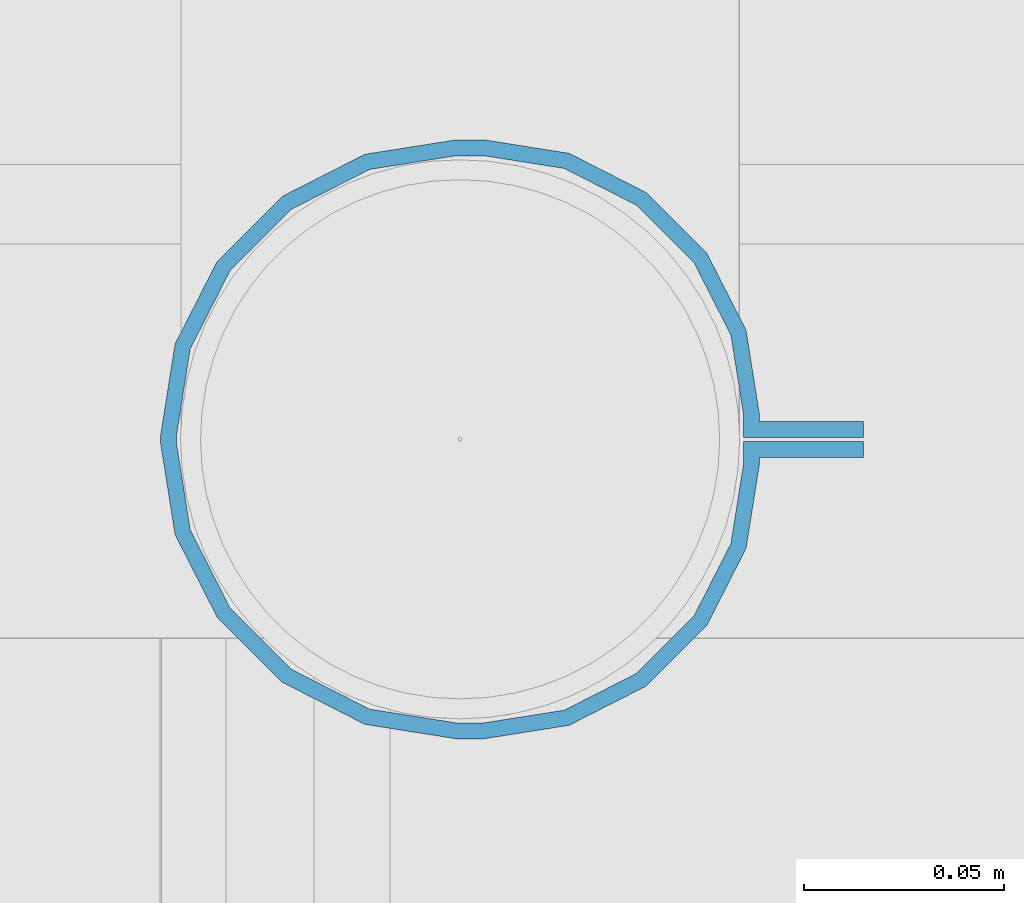
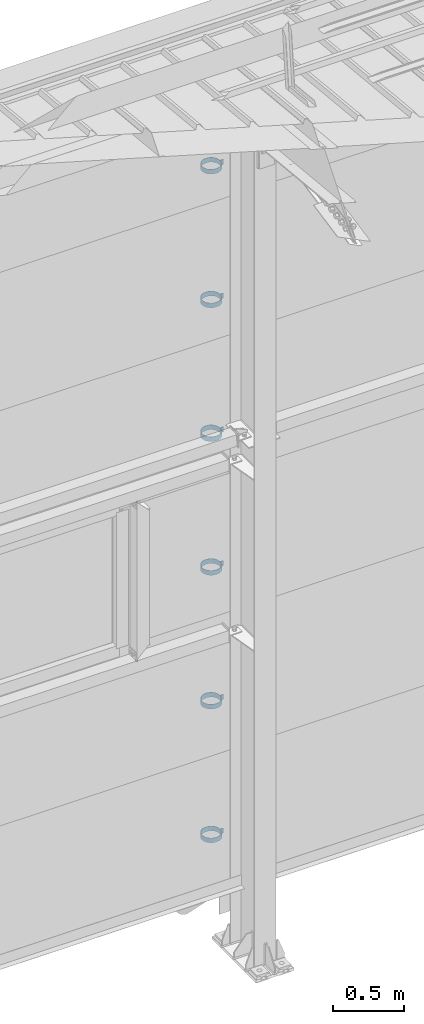
# One storey, part 319 of 709: 6 beams, 6 elements without a shape of their own.
"""IFC4 building model written with IfcOpenShell, lengths in millimetres."""

from ifc_helpers import new_model, si_unit, direction, frame, origin_with_axes, place, context, subcontext, project, spatial, polygons, material, element, aggregate, save


model = new_model("IFC4")

# Units and contexts
model_context = context("Model", 3, precision=0.2, world=origin_with_axes(), true_north=direction((0.0, 1.0)))
body_context = subcontext(model_context, "Body", "Model", "MODEL_VIEW")
ifc_project = project(units=[si_unit("LENGTHUNIT", "METRE", prefix="MILLI"), si_unit("AREAUNIT", "SQUARE_METRE"), si_unit("VOLUMEUNIT", "CUBIC_METRE"), si_unit("MASSUNIT", "GRAM", prefix="KILO"), si_unit("TIMEUNIT", "SECOND"), si_unit("PLANEANGLEUNIT", "RADIAN"), si_unit("SOLIDANGLEUNIT", "STERADIAN"), si_unit("THERMODYNAMICTEMPERATUREUNIT", "DEGREE_CELSIUS"), si_unit("LUMINOUSINTENSITYUNIT", "LUMEN")], contexts=[model_context])

# Site, building, storey
site_placement = place(None, origin_with_axes())
site = spatial("IfcSite", under=ifc_project, at=site_placement, CompositionType="ELEMENT")
building_placement = place(site_placement, origin_with_axes())
building = spatial("IfcBuilding", under=site, at=building_placement, Name="Undefined", CompositionType="ELEMENT")
storey_placement = place(building_placement, origin_with_axes())
storey = spatial("IfcBuildingStorey", under=building, at=storey_placement, Name="Undefined", CompositionType="ELEMENT", Elevation=0.0)

# Assembly, beam
assembly_1_placement = place(storey_placement, frame((34101.0, 22422.5, 6226.92297), z_axis=(0.0, 1.0, 0.0), x_axis=(-1.0, 0.0, 0.0)))
assembly_1 = element("IfcElementAssembly", 1, at=assembly_1_placement, inside=storey)
ifc_material = material(Name="Steel_Undefined", Category="STEEL")
beam_1_placement = place(assembly_1_placement, origin_with_axes())
beam_1 = element("IfcBeam", 2, at=beam_1_placement, material=ifc_material, ObjectType="616", context=body_context, shape_type="Tessellation", body=[
    polygons([(0.0, -20.0, 2.0), (0.0, 20.0, 2.0), (0.0, 20.0, -2.0), (0.0, -20.0, -2.0), (30.0, 20.0, -2.0), (30.0, -20.0, -2.0), (26.0, -20.0, 2.0), (26.0, 20.0, 2.0), (30.0, 20.0, 3.5), (30.0, -20.0, 3.5), (26.0, -20.0, 3.5), (26.0, 20.0, 3.5), (33.18133, 20.0, 23.5861), (33.18133, -20.0, 23.5861), (29.3771, -20.0, 24.82217), (29.3771, 20.0, 24.82217), (39.17783, -20.0, 44.05718), (39.17783, 20.0, 44.05718), (42.4139, 20.0, 41.70604), (42.4139, -20.0, 41.70604), (54.44282, -20.0, 59.32217), (54.44282, 20.0, 59.32217), (56.79396, 20.0, 56.0861), (56.79396, -20.0, 56.0861), (73.67783, -20.0, 69.1229), (73.67783, 20.0, 69.1229), (74.9139, 20.0, 65.31867), (74.9139, -20.0, 65.31867), (95.0, -20.0, 72.5), (95.0, 20.0, 72.5), (95.0, 20.0, 68.5), (95.0, -20.0, 68.5), (102.0, 20.0, 68.5), (102.0, -20.0, 68.5), (102.0, -20.0, 72.5), (102.0, 20.0, 72.5), (123.63119, 20.0, 65.07396), (123.63119, -20.0, 65.07396), (124.86726, -20.0, 68.87818), (124.86726, 20.0, 68.87818), (145.49611, -20.0, 58.36726), (145.49611, 20.0, 58.36726), (143.14497, 20.0, 55.13119), (143.14497, -20.0, 55.13119), (161.86726, -20.0, 41.99611), (161.86726, 20.0, 41.99611), (158.63119, 20.0, 39.64497), (158.63119, -20.0, 39.64497), (172.37818, -20.0, 21.36726), (172.37818, 20.0, 21.36726), (168.57396, 20.0, 20.13119), (168.57396, -20.0, 20.13119), (176.0, -20.0, -1.5), (176.0, 20.0, -1.5), (172.0, 20.0, -1.5), (172.0, -20.0, -1.5), (172.0, 20.0, -3.5), (172.0, -20.0, -3.5), (176.0, -20.0, -3.5), (176.0, 20.0, -3.5), (168.57396, 20.0, -25.13119), (168.57396, -20.0, -25.13119), (172.37818, -20.0, -26.36726), (172.37818, 20.0, -26.36726), (161.86726, -20.0, -46.99611), (161.86726, 20.0, -46.99611), (158.63119, 20.0, -44.64497), (158.63119, -20.0, -44.64497), (145.49611, -20.0, -63.36726), (145.49611, 20.0, -63.36726), (143.14497, 20.0, -60.13119), (143.14497, -20.0, -60.13119), (124.86726, -20.0, -73.87818), (124.86726, 20.0, -73.87818), (123.63119, 20.0, -70.07396), (123.63119, -20.0, -70.07396), (102.0, -20.0, -77.5), (102.0, 20.0, -77.5), (102.0, 20.0, -73.5), (102.0, -20.0, -73.5), (95.0, 20.0, -73.5), (95.0, -20.0, -73.5), (95.0, -20.0, -77.5), (95.0, 20.0, -77.5), (74.9139, 20.0, -70.31867), (74.9139, -20.0, -70.31867), (73.67783, -20.0, -74.1229), (73.67783, 20.0, -74.1229), (54.44282, -20.0, -64.32217), (54.44282, 20.0, -64.32217), (56.79396, 20.0, -61.0861), (56.79396, -20.0, -61.0861), (39.17783, -20.0, -49.05718), (39.17783, 20.0, -49.05718), (42.4139, 20.0, -46.70604), (42.4139, -20.0, -46.70604), (29.3771, -20.0, -29.82217), (29.3771, 20.0, -29.82217), (33.18133, 20.0, -28.5861), (33.18133, -20.0, -28.5861), (26.0, -20.0, -8.5), (26.0, 20.0, -8.5), (30.0, 20.0, -8.5), (30.0, -20.0, -8.5), (30.0, 20.0, -3.0), (30.0, -20.0, -3.0), (26.0, -20.0, -7.0), (26.0, 20.0, -7.0), (0.0, 20.0, -3.0), (0.0, -20.0, -3.0), (0.0, 20.0, -7.0), (0.0, -20.0, -7.0)], [[[1, 2, 3, 4]], [[4, 3, 5, 6]], [[2, 1, 7, 8]], [[6, 5, 9, 10]], [[8, 7, 11, 12]], [[10, 9, 13, 14]], [[12, 11, 15, 16]], [[15, 17, 18, 16]], [[13, 19, 20, 14]], [[17, 21, 22, 18]], [[19, 23, 24, 20]], [[21, 25, 26, 22]], [[23, 27, 28, 24]], [[25, 29, 30, 26]], [[27, 31, 32, 28]], [[32, 31, 33, 34]], [[30, 29, 35, 36]], [[34, 33, 37, 38]], [[36, 35, 39, 40]], [[39, 41, 42, 40]], [[37, 43, 44, 38]], [[41, 45, 46, 42]], [[43, 47, 48, 44]], [[45, 49, 50, 46]], [[47, 51, 52, 48]], [[49, 53, 54, 50]], [[51, 55, 56, 52]], [[56, 55, 57, 58]], [[54, 53, 59, 60]], [[58, 57, 61, 62]], [[60, 59, 63, 64]], [[63, 65, 66, 64]], [[61, 67, 68, 62]], [[65, 69, 70, 66]], [[67, 71, 72, 68]], [[69, 73, 74, 70]], [[71, 75, 76, 72]], [[73, 77, 78, 74]], [[75, 79, 80, 76]], [[80, 79, 81, 82]], [[78, 77, 83, 84]], [[82, 81, 85, 86]], [[84, 83, 87, 88]], [[87, 89, 90, 88]], [[85, 91, 92, 86]], [[89, 93, 94, 90]], [[91, 95, 96, 92]], [[93, 97, 98, 94]], [[95, 99, 100, 96]], [[97, 101, 102, 98]], [[99, 103, 104, 100]], [[104, 103, 105, 106]], [[102, 101, 107, 108]], [[106, 105, 109, 110]], [[105, 103, 99, 95, 91, 85, 81, 79, 75, 71, 67, 61, 57, 55, 51, 47, 43, 37, 33, 31, 27, 23, 19, 13, 9, 5, 3, 2, 8, 12, 16, 18, 22, 26, 30, 36, 40, 42, 46, 50, 54, 60, 64, 66, 70, 74, 78, 84, 88, 90, 94, 98, 102, 108, 111, 109]], [[108, 107, 112, 111]], [[107, 101, 97, 93, 89, 87, 83, 77, 73, 69, 65, 63, 59, 53, 49, 45, 41, 39, 35, 29, 25, 21, 17, 15, 11, 7, 1, 4, 6, 10, 14, 20, 24, 28, 32, 34, 38, 44, 48, 52, 56, 58, 62, 68, 72, 76, 80, 82, 86, 92, 96, 100, 104, 106, 110, 112]], [[111, 112, 110, 109]]], closed=True),
])
aggregate(assembly_1, [beam_1])

assembly_2_placement = place(storey_placement, frame((34101.0, 22422.5, 5076.92297), z_axis=(0.0, 1.0, 0.0), x_axis=(-1.0, 0.0, 0.0)))
assembly_2 = element("IfcElementAssembly", 3, at=assembly_2_placement, inside=storey)
beam_2_placement = place(assembly_2_placement, origin_with_axes())
beam_2 = element("IfcBeam", 4, at=beam_2_placement, material=ifc_material, ObjectType="616", context=body_context, shape_type="Tessellation", body=[
    polygons([(0.0, -20.0, 2.0), (0.0, 20.0, 2.0), (0.0, 20.0, -2.0), (0.0, -20.0, -2.0), (30.0, 20.0, -2.0), (30.0, -20.0, -2.0), (26.0, -20.0, 2.0), (26.0, 20.0, 2.0), (30.0, 20.0, 3.5), (30.0, -20.0, 3.5), (26.0, -20.0, 3.5), (26.0, 20.0, 3.5), (33.18133, 20.0, 23.5861), (33.18133, -20.0, 23.5861), (29.3771, -20.0, 24.82217), (29.3771, 20.0, 24.82217), (39.17783, -20.0, 44.05718), (39.17783, 20.0, 44.05718), (42.4139, 20.0, 41.70604), (42.4139, -20.0, 41.70604), (54.44282, -20.0, 59.32217), (54.44282, 20.0, 59.32217), (56.79396, 20.0, 56.0861), (56.79396, -20.0, 56.0861), (73.67783, -20.0, 69.1229), (73.67783, 20.0, 69.1229), (74.9139, 20.0, 65.31867), (74.9139, -20.0, 65.31867), (95.0, -20.0, 72.5), (95.0, 20.0, 72.5), (95.0, 20.0, 68.5), (95.0, -20.0, 68.5), (102.0, 20.0, 68.5), (102.0, -20.0, 68.5), (102.0, -20.0, 72.5), (102.0, 20.0, 72.5), (123.63119, 20.0, 65.07396), (123.63119, -20.0, 65.07396), (124.86726, -20.0, 68.87818), (124.86726, 20.0, 68.87818), (145.49611, -20.0, 58.36726), (145.49611, 20.0, 58.36726), (143.14497, 20.0, 55.13119), (143.14497, -20.0, 55.13119), (161.86726, -20.0, 41.99611), (161.86726, 20.0, 41.99611), (158.63119, 20.0, 39.64497), (158.63119, -20.0, 39.64497), (172.37818, -20.0, 21.36726), (172.37818, 20.0, 21.36726), (168.57396, 20.0, 20.13119), (168.57396, -20.0, 20.13119), (176.0, -20.0, -1.5), (176.0, 20.0, -1.5), (172.0, 20.0, -1.5), (172.0, -20.0, -1.5), (172.0, 20.0, -3.5), (172.0, -20.0, -3.5), (176.0, -20.0, -3.5), (176.0, 20.0, -3.5), (168.57396, 20.0, -25.13119), (168.57396, -20.0, -25.13119), (172.37818, -20.0, -26.36726), (172.37818, 20.0, -26.36726), (161.86726, -20.0, -46.99611), (161.86726, 20.0, -46.99611), (158.63119, 20.0, -44.64497), (158.63119, -20.0, -44.64497), (145.49611, -20.0, -63.36726), (145.49611, 20.0, -63.36726), (143.14497, 20.0, -60.13119), (143.14497, -20.0, -60.13119), (124.86726, -20.0, -73.87818), (124.86726, 20.0, -73.87818), (123.63119, 20.0, -70.07396), (123.63119, -20.0, -70.07396), (102.0, -20.0, -77.5), (102.0, 20.0, -77.5), (102.0, 20.0, -73.5), (102.0, -20.0, -73.5), (95.0, 20.0, -73.5), (95.0, -20.0, -73.5), (95.0, -20.0, -77.5), (95.0, 20.0, -77.5), (74.9139, 20.0, -70.31867), (74.9139, -20.0, -70.31867), (73.67783, -20.0, -74.1229), (73.67783, 20.0, -74.1229), (54.44282, -20.0, -64.32217), (54.44282, 20.0, -64.32217), (56.79396, 20.0, -61.0861), (56.79396, -20.0, -61.0861), (39.17783, -20.0, -49.05718), (39.17783, 20.0, -49.05718), (42.4139, 20.0, -46.70604), (42.4139, -20.0, -46.70604), (29.3771, -20.0, -29.82217), (29.3771, 20.0, -29.82217), (33.18133, 20.0, -28.5861), (33.18133, -20.0, -28.5861), (26.0, -20.0, -8.5), (26.0, 20.0, -8.5), (30.0, 20.0, -8.5), (30.0, -20.0, -8.5), (30.0, 20.0, -3.0), (30.0, -20.0, -3.0), (26.0, -20.0, -7.0), (26.0, 20.0, -7.0), (0.0, 20.0, -3.0), (0.0, -20.0, -3.0), (0.0, 20.0, -7.0), (0.0, -20.0, -7.0)], [[[1, 2, 3, 4]], [[4, 3, 5, 6]], [[2, 1, 7, 8]], [[6, 5, 9, 10]], [[8, 7, 11, 12]], [[10, 9, 13, 14]], [[12, 11, 15, 16]], [[15, 17, 18, 16]], [[13, 19, 20, 14]], [[17, 21, 22, 18]], [[19, 23, 24, 20]], [[21, 25, 26, 22]], [[23, 27, 28, 24]], [[25, 29, 30, 26]], [[27, 31, 32, 28]], [[32, 31, 33, 34]], [[30, 29, 35, 36]], [[34, 33, 37, 38]], [[36, 35, 39, 40]], [[39, 41, 42, 40]], [[37, 43, 44, 38]], [[41, 45, 46, 42]], [[43, 47, 48, 44]], [[45, 49, 50, 46]], [[47, 51, 52, 48]], [[49, 53, 54, 50]], [[51, 55, 56, 52]], [[56, 55, 57, 58]], [[54, 53, 59, 60]], [[58, 57, 61, 62]], [[60, 59, 63, 64]], [[63, 65, 66, 64]], [[61, 67, 68, 62]], [[65, 69, 70, 66]], [[67, 71, 72, 68]], [[69, 73, 74, 70]], [[71, 75, 76, 72]], [[73, 77, 78, 74]], [[75, 79, 80, 76]], [[80, 79, 81, 82]], [[78, 77, 83, 84]], [[82, 81, 85, 86]], [[84, 83, 87, 88]], [[87, 89, 90, 88]], [[85, 91, 92, 86]], [[89, 93, 94, 90]], [[91, 95, 96, 92]], [[93, 97, 98, 94]], [[95, 99, 100, 96]], [[97, 101, 102, 98]], [[99, 103, 104, 100]], [[104, 103, 105, 106]], [[102, 101, 107, 108]], [[106, 105, 109, 110]], [[105, 103, 99, 95, 91, 85, 81, 79, 75, 71, 67, 61, 57, 55, 51, 47, 43, 37, 33, 31, 27, 23, 19, 13, 9, 5, 3, 2, 8, 12, 16, 18, 22, 26, 30, 36, 40, 42, 46, 50, 54, 60, 64, 66, 70, 74, 78, 84, 88, 90, 94, 98, 102, 108, 111, 109]], [[108, 107, 112, 111]], [[107, 101, 97, 93, 89, 87, 83, 77, 73, 69, 65, 63, 59, 53, 49, 45, 41, 39, 35, 29, 25, 21, 17, 15, 11, 7, 1, 4, 6, 10, 14, 20, 24, 28, 32, 34, 38, 44, 48, 52, 56, 58, 62, 68, 72, 76, 80, 82, 86, 92, 96, 100, 104, 106, 110, 112]], [[111, 112, 110, 109]]], closed=True),
])
aggregate(assembly_2, [beam_2])

assembly_3_placement = place(storey_placement, frame((34101.0, 22422.5, 3926.92297), z_axis=(0.0, 1.0, 0.0), x_axis=(-1.0, 0.0, 0.0)))
assembly_3 = element("IfcElementAssembly", 5, at=assembly_3_placement, inside=storey)
beam_3_placement = place(assembly_3_placement, origin_with_axes())
beam_3 = element("IfcBeam", 6, at=beam_3_placement, material=ifc_material, ObjectType="616", context=body_context, shape_type="Tessellation", body=[
    polygons([(0.0, -20.0, 2.0), (0.0, 20.0, 2.0), (0.0, 20.0, -2.0), (0.0, -20.0, -2.0), (30.0, 20.0, -2.0), (30.0, -20.0, -2.0), (26.0, -20.0, 2.0), (26.0, 20.0, 2.0), (30.0, 20.0, 3.5), (30.0, -20.0, 3.5), (26.0, -20.0, 3.5), (26.0, 20.0, 3.5), (33.18133, 20.0, 23.5861), (33.18133, -20.0, 23.5861), (29.3771, -20.0, 24.82217), (29.3771, 20.0, 24.82217), (39.17783, -20.0, 44.05718), (39.17783, 20.0, 44.05718), (42.4139, 20.0, 41.70604), (42.4139, -20.0, 41.70604), (54.44282, -20.0, 59.32217), (54.44282, 20.0, 59.32217), (56.79396, 20.0, 56.0861), (56.79396, -20.0, 56.0861), (73.67783, -20.0, 69.1229), (73.67783, 20.0, 69.1229), (74.9139, 20.0, 65.31867), (74.9139, -20.0, 65.31867), (95.0, -20.0, 72.5), (95.0, 20.0, 72.5), (95.0, 20.0, 68.5), (95.0, -20.0, 68.5), (102.0, 20.0, 68.5), (102.0, -20.0, 68.5), (102.0, -20.0, 72.5), (102.0, 20.0, 72.5), (123.63119, 20.0, 65.07396), (123.63119, -20.0, 65.07396), (124.86726, -20.0, 68.87818), (124.86726, 20.0, 68.87818), (145.49611, -20.0, 58.36726), (145.49611, 20.0, 58.36726), (143.14497, 20.0, 55.13119), (143.14497, -20.0, 55.13119), (161.86726, -20.0, 41.99611), (161.86726, 20.0, 41.99611), (158.63119, 20.0, 39.64497), (158.63119, -20.0, 39.64497), (172.37818, -20.0, 21.36726), (172.37818, 20.0, 21.36726), (168.57396, 20.0, 20.13119), (168.57396, -20.0, 20.13119), (176.0, -20.0, -1.5), (176.0, 20.0, -1.5), (172.0, 20.0, -1.5), (172.0, -20.0, -1.5), (172.0, 20.0, -3.5), (172.0, -20.0, -3.5), (176.0, -20.0, -3.5), (176.0, 20.0, -3.5), (168.57396, 20.0, -25.13119), (168.57396, -20.0, -25.13119), (172.37818, -20.0, -26.36726), (172.37818, 20.0, -26.36726), (161.86726, -20.0, -46.99611), (161.86726, 20.0, -46.99611), (158.63119, 20.0, -44.64497), (158.63119, -20.0, -44.64497), (145.49611, -20.0, -63.36726), (145.49611, 20.0, -63.36726), (143.14497, 20.0, -60.13119), (143.14497, -20.0, -60.13119), (124.86726, -20.0, -73.87818), (124.86726, 20.0, -73.87818), (123.63119, 20.0, -70.07396), (123.63119, -20.0, -70.07396), (102.0, -20.0, -77.5), (102.0, 20.0, -77.5), (102.0, 20.0, -73.5), (102.0, -20.0, -73.5), (95.0, 20.0, -73.5), (95.0, -20.0, -73.5), (95.0, -20.0, -77.5), (95.0, 20.0, -77.5), (74.9139, 20.0, -70.31867), (74.9139, -20.0, -70.31867), (73.67783, -20.0, -74.1229), (73.67783, 20.0, -74.1229), (54.44282, -20.0, -64.32217), (54.44282, 20.0, -64.32217), (56.79396, 20.0, -61.0861), (56.79396, -20.0, -61.0861), (39.17783, -20.0, -49.05718), (39.17783, 20.0, -49.05718), (42.4139, 20.0, -46.70604), (42.4139, -20.0, -46.70604), (29.3771, -20.0, -29.82217), (29.3771, 20.0, -29.82217), (33.18133, 20.0, -28.5861), (33.18133, -20.0, -28.5861), (26.0, -20.0, -8.5), (26.0, 20.0, -8.5), (30.0, 20.0, -8.5), (30.0, -20.0, -8.5), (30.0, 20.0, -3.0), (30.0, -20.0, -3.0), (26.0, -20.0, -7.0), (26.0, 20.0, -7.0), (0.0, 20.0, -3.0), (0.0, -20.0, -3.0), (0.0, 20.0, -7.0), (0.0, -20.0, -7.0)], [[[1, 2, 3, 4]], [[4, 3, 5, 6]], [[2, 1, 7, 8]], [[6, 5, 9, 10]], [[8, 7, 11, 12]], [[10, 9, 13, 14]], [[12, 11, 15, 16]], [[15, 17, 18, 16]], [[13, 19, 20, 14]], [[17, 21, 22, 18]], [[19, 23, 24, 20]], [[21, 25, 26, 22]], [[23, 27, 28, 24]], [[25, 29, 30, 26]], [[27, 31, 32, 28]], [[32, 31, 33, 34]], [[30, 29, 35, 36]], [[34, 33, 37, 38]], [[36, 35, 39, 40]], [[39, 41, 42, 40]], [[37, 43, 44, 38]], [[41, 45, 46, 42]], [[43, 47, 48, 44]], [[45, 49, 50, 46]], [[47, 51, 52, 48]], [[49, 53, 54, 50]], [[51, 55, 56, 52]], [[56, 55, 57, 58]], [[54, 53, 59, 60]], [[58, 57, 61, 62]], [[60, 59, 63, 64]], [[63, 65, 66, 64]], [[61, 67, 68, 62]], [[65, 69, 70, 66]], [[67, 71, 72, 68]], [[69, 73, 74, 70]], [[71, 75, 76, 72]], [[73, 77, 78, 74]], [[75, 79, 80, 76]], [[80, 79, 81, 82]], [[78, 77, 83, 84]], [[82, 81, 85, 86]], [[84, 83, 87, 88]], [[87, 89, 90, 88]], [[85, 91, 92, 86]], [[89, 93, 94, 90]], [[91, 95, 96, 92]], [[93, 97, 98, 94]], [[95, 99, 100, 96]], [[97, 101, 102, 98]], [[99, 103, 104, 100]], [[104, 103, 105, 106]], [[102, 101, 107, 108]], [[106, 105, 109, 110]], [[105, 103, 99, 95, 91, 85, 81, 79, 75, 71, 67, 61, 57, 55, 51, 47, 43, 37, 33, 31, 27, 23, 19, 13, 9, 5, 3, 2, 8, 12, 16, 18, 22, 26, 30, 36, 40, 42, 46, 50, 54, 60, 64, 66, 70, 74, 78, 84, 88, 90, 94, 98, 102, 108, 111, 109]], [[108, 107, 112, 111]], [[107, 101, 97, 93, 89, 87, 83, 77, 73, 69, 65, 63, 59, 53, 49, 45, 41, 39, 35, 29, 25, 21, 17, 15, 11, 7, 1, 4, 6, 10, 14, 20, 24, 28, 32, 34, 38, 44, 48, 52, 56, 58, 62, 68, 72, 76, 80, 82, 86, 92, 96, 100, 104, 106, 110, 112]], [[111, 112, 110, 109]]], closed=True),
])
aggregate(assembly_3, [beam_3])

assembly_4_placement = place(storey_placement, frame((34101.0, 22422.5, 2776.92297), z_axis=(0.0, 1.0, 0.0), x_axis=(-1.0, 0.0, 0.0)))
assembly_4 = element("IfcElementAssembly", 7, at=assembly_4_placement, inside=storey)
beam_4_placement = place(assembly_4_placement, origin_with_axes())
beam_4 = element("IfcBeam", 8, at=beam_4_placement, material=ifc_material, ObjectType="616", context=body_context, shape_type="Tessellation", body=[
    polygons([(0.0, -20.0, 2.0), (0.0, 20.0, 2.0), (0.0, 20.0, -2.0), (0.0, -20.0, -2.0), (30.0, 20.0, -2.0), (30.0, -20.0, -2.0), (26.0, -20.0, 2.0), (26.0, 20.0, 2.0), (30.0, 20.0, 3.5), (30.0, -20.0, 3.5), (26.0, -20.0, 3.5), (26.0, 20.0, 3.5), (33.18133, 20.0, 23.5861), (33.18133, -20.0, 23.5861), (29.3771, -20.0, 24.82217), (29.3771, 20.0, 24.82217), (39.17783, -20.0, 44.05718), (39.17783, 20.0, 44.05718), (42.4139, 20.0, 41.70604), (42.4139, -20.0, 41.70604), (54.44282, -20.0, 59.32217), (54.44282, 20.0, 59.32217), (56.79396, 20.0, 56.0861), (56.79396, -20.0, 56.0861), (73.67783, -20.0, 69.1229), (73.67783, 20.0, 69.1229), (74.9139, 20.0, 65.31867), (74.9139, -20.0, 65.31867), (95.0, -20.0, 72.5), (95.0, 20.0, 72.5), (95.0, 20.0, 68.5), (95.0, -20.0, 68.5), (102.0, 20.0, 68.5), (102.0, -20.0, 68.5), (102.0, -20.0, 72.5), (102.0, 20.0, 72.5), (123.63119, 20.0, 65.07396), (123.63119, -20.0, 65.07396), (124.86726, -20.0, 68.87818), (124.86726, 20.0, 68.87818), (145.49611, -20.0, 58.36726), (145.49611, 20.0, 58.36726), (143.14497, 20.0, 55.13119), (143.14497, -20.0, 55.13119), (161.86726, -20.0, 41.99611), (161.86726, 20.0, 41.99611), (158.63119, 20.0, 39.64497), (158.63119, -20.0, 39.64497), (172.37818, -20.0, 21.36726), (172.37818, 20.0, 21.36726), (168.57396, 20.0, 20.13119), (168.57396, -20.0, 20.13119), (176.0, -20.0, -1.5), (176.0, 20.0, -1.5), (172.0, 20.0, -1.5), (172.0, -20.0, -1.5), (172.0, 20.0, -3.5), (172.0, -20.0, -3.5), (176.0, -20.0, -3.5), (176.0, 20.0, -3.5), (168.57396, 20.0, -25.13119), (168.57396, -20.0, -25.13119), (172.37818, -20.0, -26.36726), (172.37818, 20.0, -26.36726), (161.86726, -20.0, -46.99611), (161.86726, 20.0, -46.99611), (158.63119, 20.0, -44.64497), (158.63119, -20.0, -44.64497), (145.49611, -20.0, -63.36726), (145.49611, 20.0, -63.36726), (143.14497, 20.0, -60.13119), (143.14497, -20.0, -60.13119), (124.86726, -20.0, -73.87818), (124.86726, 20.0, -73.87818), (123.63119, 20.0, -70.07396), (123.63119, -20.0, -70.07396), (102.0, -20.0, -77.5), (102.0, 20.0, -77.5), (102.0, 20.0, -73.5), (102.0, -20.0, -73.5), (95.0, 20.0, -73.5), (95.0, -20.0, -73.5), (95.0, -20.0, -77.5), (95.0, 20.0, -77.5), (74.9139, 20.0, -70.31867), (74.9139, -20.0, -70.31867), (73.67783, -20.0, -74.1229), (73.67783, 20.0, -74.1229), (54.44282, -20.0, -64.32217), (54.44282, 20.0, -64.32217), (56.79396, 20.0, -61.0861), (56.79396, -20.0, -61.0861), (39.17783, -20.0, -49.05718), (39.17783, 20.0, -49.05718), (42.4139, 20.0, -46.70604), (42.4139, -20.0, -46.70604), (29.3771, -20.0, -29.82217), (29.3771, 20.0, -29.82217), (33.18133, 20.0, -28.5861), (33.18133, -20.0, -28.5861), (26.0, -20.0, -8.5), (26.0, 20.0, -8.5), (30.0, 20.0, -8.5), (30.0, -20.0, -8.5), (30.0, 20.0, -3.0), (30.0, -20.0, -3.0), (26.0, -20.0, -7.0), (26.0, 20.0, -7.0), (0.0, 20.0, -3.0), (0.0, -20.0, -3.0), (0.0, 20.0, -7.0), (0.0, -20.0, -7.0)], [[[1, 2, 3, 4]], [[4, 3, 5, 6]], [[2, 1, 7, 8]], [[6, 5, 9, 10]], [[8, 7, 11, 12]], [[10, 9, 13, 14]], [[12, 11, 15, 16]], [[15, 17, 18, 16]], [[13, 19, 20, 14]], [[17, 21, 22, 18]], [[19, 23, 24, 20]], [[21, 25, 26, 22]], [[23, 27, 28, 24]], [[25, 29, 30, 26]], [[27, 31, 32, 28]], [[32, 31, 33, 34]], [[30, 29, 35, 36]], [[34, 33, 37, 38]], [[36, 35, 39, 40]], [[39, 41, 42, 40]], [[37, 43, 44, 38]], [[41, 45, 46, 42]], [[43, 47, 48, 44]], [[45, 49, 50, 46]], [[47, 51, 52, 48]], [[49, 53, 54, 50]], [[51, 55, 56, 52]], [[56, 55, 57, 58]], [[54, 53, 59, 60]], [[58, 57, 61, 62]], [[60, 59, 63, 64]], [[63, 65, 66, 64]], [[61, 67, 68, 62]], [[65, 69, 70, 66]], [[67, 71, 72, 68]], [[69, 73, 74, 70]], [[71, 75, 76, 72]], [[73, 77, 78, 74]], [[75, 79, 80, 76]], [[80, 79, 81, 82]], [[78, 77, 83, 84]], [[82, 81, 85, 86]], [[84, 83, 87, 88]], [[87, 89, 90, 88]], [[85, 91, 92, 86]], [[89, 93, 94, 90]], [[91, 95, 96, 92]], [[93, 97, 98, 94]], [[95, 99, 100, 96]], [[97, 101, 102, 98]], [[99, 103, 104, 100]], [[104, 103, 105, 106]], [[102, 101, 107, 108]], [[106, 105, 109, 110]], [[105, 103, 99, 95, 91, 85, 81, 79, 75, 71, 67, 61, 57, 55, 51, 47, 43, 37, 33, 31, 27, 23, 19, 13, 9, 5, 3, 2, 8, 12, 16, 18, 22, 26, 30, 36, 40, 42, 46, 50, 54, 60, 64, 66, 70, 74, 78, 84, 88, 90, 94, 98, 102, 108, 111, 109]], [[108, 107, 112, 111]], [[107, 101, 97, 93, 89, 87, 83, 77, 73, 69, 65, 63, 59, 53, 49, 45, 41, 39, 35, 29, 25, 21, 17, 15, 11, 7, 1, 4, 6, 10, 14, 20, 24, 28, 32, 34, 38, 44, 48, 52, 56, 58, 62, 68, 72, 76, 80, 82, 86, 92, 96, 100, 104, 106, 110, 112]], [[111, 112, 110, 109]]], closed=True),
])
aggregate(assembly_4, [beam_4])

assembly_5_placement = place(storey_placement, frame((34101.0, 22422.5, 1626.92297), z_axis=(0.0, 1.0, 0.0), x_axis=(-1.0, 0.0, 0.0)))
assembly_5 = element("IfcElementAssembly", 9, at=assembly_5_placement, inside=storey)
beam_5_placement = place(assembly_5_placement, origin_with_axes())
beam_5 = element("IfcBeam", 10, at=beam_5_placement, material=ifc_material, ObjectType="616", context=body_context, shape_type="Tessellation", body=[
    polygons([(0.0, -20.0, 2.0), (0.0, 20.0, 2.0), (0.0, 20.0, -2.0), (0.0, -20.0, -2.0), (30.0, 20.0, -2.0), (30.0, -20.0, -2.0), (26.0, -20.0, 2.0), (26.0, 20.0, 2.0), (30.0, 20.0, 3.5), (30.0, -20.0, 3.5), (26.0, -20.0, 3.5), (26.0, 20.0, 3.5), (33.18133, 20.0, 23.5861), (33.18133, -20.0, 23.5861), (29.3771, -20.0, 24.82217), (29.3771, 20.0, 24.82217), (39.17783, -20.0, 44.05718), (39.17783, 20.0, 44.05718), (42.4139, 20.0, 41.70604), (42.4139, -20.0, 41.70604), (54.44282, -20.0, 59.32217), (54.44282, 20.0, 59.32217), (56.79396, 20.0, 56.0861), (56.79396, -20.0, 56.0861), (73.67783, -20.0, 69.1229), (73.67783, 20.0, 69.1229), (74.9139, 20.0, 65.31867), (74.9139, -20.0, 65.31867), (95.0, -20.0, 72.5), (95.0, 20.0, 72.5), (95.0, 20.0, 68.5), (95.0, -20.0, 68.5), (102.0, 20.0, 68.5), (102.0, -20.0, 68.5), (102.0, -20.0, 72.5), (102.0, 20.0, 72.5), (123.63119, 20.0, 65.07396), (123.63119, -20.0, 65.07396), (124.86726, -20.0, 68.87818), (124.86726, 20.0, 68.87818), (145.49611, -20.0, 58.36726), (145.49611, 20.0, 58.36726), (143.14497, 20.0, 55.13119), (143.14497, -20.0, 55.13119), (161.86726, -20.0, 41.99611), (161.86726, 20.0, 41.99611), (158.63119, 20.0, 39.64497), (158.63119, -20.0, 39.64497), (172.37818, -20.0, 21.36726), (172.37818, 20.0, 21.36726), (168.57396, 20.0, 20.13119), (168.57396, -20.0, 20.13119), (176.0, -20.0, -1.5), (176.0, 20.0, -1.5), (172.0, 20.0, -1.5), (172.0, -20.0, -1.5), (172.0, 20.0, -3.5), (172.0, -20.0, -3.5), (176.0, -20.0, -3.5), (176.0, 20.0, -3.5), (168.57396, 20.0, -25.13119), (168.57396, -20.0, -25.13119), (172.37818, -20.0, -26.36726), (172.37818, 20.0, -26.36726), (161.86726, -20.0, -46.99611), (161.86726, 20.0, -46.99611), (158.63119, 20.0, -44.64497), (158.63119, -20.0, -44.64497), (145.49611, -20.0, -63.36726), (145.49611, 20.0, -63.36726), (143.14497, 20.0, -60.13119), (143.14497, -20.0, -60.13119), (124.86726, -20.0, -73.87818), (124.86726, 20.0, -73.87818), (123.63119, 20.0, -70.07396), (123.63119, -20.0, -70.07396), (102.0, -20.0, -77.5), (102.0, 20.0, -77.5), (102.0, 20.0, -73.5), (102.0, -20.0, -73.5), (95.0, 20.0, -73.5), (95.0, -20.0, -73.5), (95.0, -20.0, -77.5), (95.0, 20.0, -77.5), (74.9139, 20.0, -70.31867), (74.9139, -20.0, -70.31867), (73.67783, -20.0, -74.1229), (73.67783, 20.0, -74.1229), (54.44282, -20.0, -64.32217), (54.44282, 20.0, -64.32217), (56.79396, 20.0, -61.0861), (56.79396, -20.0, -61.0861), (39.17783, -20.0, -49.05718), (39.17783, 20.0, -49.05718), (42.4139, 20.0, -46.70604), (42.4139, -20.0, -46.70604), (29.3771, -20.0, -29.82217), (29.3771, 20.0, -29.82217), (33.18133, 20.0, -28.5861), (33.18133, -20.0, -28.5861), (26.0, -20.0, -8.5), (26.0, 20.0, -8.5), (30.0, 20.0, -8.5), (30.0, -20.0, -8.5), (30.0, 20.0, -3.0), (30.0, -20.0, -3.0), (26.0, -20.0, -7.0), (26.0, 20.0, -7.0), (0.0, 20.0, -3.0), (0.0, -20.0, -3.0), (0.0, 20.0, -7.0), (0.0, -20.0, -7.0)], [[[1, 2, 3, 4]], [[4, 3, 5, 6]], [[2, 1, 7, 8]], [[6, 5, 9, 10]], [[8, 7, 11, 12]], [[10, 9, 13, 14]], [[12, 11, 15, 16]], [[15, 17, 18, 16]], [[13, 19, 20, 14]], [[17, 21, 22, 18]], [[19, 23, 24, 20]], [[21, 25, 26, 22]], [[23, 27, 28, 24]], [[25, 29, 30, 26]], [[27, 31, 32, 28]], [[32, 31, 33, 34]], [[30, 29, 35, 36]], [[34, 33, 37, 38]], [[36, 35, 39, 40]], [[39, 41, 42, 40]], [[37, 43, 44, 38]], [[41, 45, 46, 42]], [[43, 47, 48, 44]], [[45, 49, 50, 46]], [[47, 51, 52, 48]], [[49, 53, 54, 50]], [[51, 55, 56, 52]], [[56, 55, 57, 58]], [[54, 53, 59, 60]], [[58, 57, 61, 62]], [[60, 59, 63, 64]], [[63, 65, 66, 64]], [[61, 67, 68, 62]], [[65, 69, 70, 66]], [[67, 71, 72, 68]], [[69, 73, 74, 70]], [[71, 75, 76, 72]], [[73, 77, 78, 74]], [[75, 79, 80, 76]], [[80, 79, 81, 82]], [[78, 77, 83, 84]], [[82, 81, 85, 86]], [[84, 83, 87, 88]], [[87, 89, 90, 88]], [[85, 91, 92, 86]], [[89, 93, 94, 90]], [[91, 95, 96, 92]], [[93, 97, 98, 94]], [[95, 99, 100, 96]], [[97, 101, 102, 98]], [[99, 103, 104, 100]], [[104, 103, 105, 106]], [[102, 101, 107, 108]], [[106, 105, 109, 110]], [[105, 103, 99, 95, 91, 85, 81, 79, 75, 71, 67, 61, 57, 55, 51, 47, 43, 37, 33, 31, 27, 23, 19, 13, 9, 5, 3, 2, 8, 12, 16, 18, 22, 26, 30, 36, 40, 42, 46, 50, 54, 60, 64, 66, 70, 74, 78, 84, 88, 90, 94, 98, 102, 108, 111, 109]], [[108, 107, 112, 111]], [[107, 101, 97, 93, 89, 87, 83, 77, 73, 69, 65, 63, 59, 53, 49, 45, 41, 39, 35, 29, 25, 21, 17, 15, 11, 7, 1, 4, 6, 10, 14, 20, 24, 28, 32, 34, 38, 44, 48, 52, 56, 58, 62, 68, 72, 76, 80, 82, 86, 92, 96, 100, 104, 106, 110, 112]], [[111, 112, 110, 109]]], closed=True),
])
aggregate(assembly_5, [beam_5])

assembly_6_placement = place(storey_placement, frame((34101.0, 22422.5, 476.92297), z_axis=(0.0, 1.0, 0.0), x_axis=(-1.0, 0.0, 0.0)))
assembly_6 = element("IfcElementAssembly", 11, at=assembly_6_placement, inside=storey)
beam_6_placement = place(assembly_6_placement, origin_with_axes())
beam_6 = element("IfcBeam", 12, at=beam_6_placement, material=ifc_material, ObjectType="616", context=body_context, shape_type="Tessellation", body=[
    polygons([(0.0, -20.0, 2.0), (0.0, 20.0, 2.0), (0.0, 20.0, -2.0), (0.0, -20.0, -2.0), (30.0, 20.0, -2.0), (30.0, -20.0, -2.0), (26.0, -20.0, 2.0), (26.0, 20.0, 2.0), (30.0, 20.0, 3.5), (30.0, -20.0, 3.5), (26.0, -20.0, 3.5), (26.0, 20.0, 3.5), (33.18133, 20.0, 23.5861), (33.18133, -20.0, 23.5861), (29.3771, -20.0, 24.82217), (29.3771, 20.0, 24.82217), (39.17783, -20.0, 44.05718), (39.17783, 20.0, 44.05718), (42.4139, 20.0, 41.70604), (42.4139, -20.0, 41.70604), (54.44282, -20.0, 59.32217), (54.44282, 20.0, 59.32217), (56.79396, 20.0, 56.0861), (56.79396, -20.0, 56.0861), (73.67783, -20.0, 69.1229), (73.67783, 20.0, 69.1229), (74.9139, 20.0, 65.31867), (74.9139, -20.0, 65.31867), (95.0, -20.0, 72.5), (95.0, 20.0, 72.5), (95.0, 20.0, 68.5), (95.0, -20.0, 68.5), (102.0, 20.0, 68.5), (102.0, -20.0, 68.5), (102.0, -20.0, 72.5), (102.0, 20.0, 72.5), (123.63119, 20.0, 65.07396), (123.63119, -20.0, 65.07396), (124.86726, -20.0, 68.87818), (124.86726, 20.0, 68.87818), (145.49611, -20.0, 58.36726), (145.49611, 20.0, 58.36726), (143.14497, 20.0, 55.13119), (143.14497, -20.0, 55.13119), (161.86726, -20.0, 41.99611), (161.86726, 20.0, 41.99611), (158.63119, 20.0, 39.64497), (158.63119, -20.0, 39.64497), (172.37818, -20.0, 21.36726), (172.37818, 20.0, 21.36726), (168.57396, 20.0, 20.13119), (168.57396, -20.0, 20.13119), (176.0, -20.0, -1.5), (176.0, 20.0, -1.5), (172.0, 20.0, -1.5), (172.0, -20.0, -1.5), (172.0, 20.0, -3.5), (172.0, -20.0, -3.5), (176.0, -20.0, -3.5), (176.0, 20.0, -3.5), (168.57396, 20.0, -25.13119), (168.57396, -20.0, -25.13119), (172.37818, -20.0, -26.36726), (172.37818, 20.0, -26.36726), (161.86726, -20.0, -46.99611), (161.86726, 20.0, -46.99611), (158.63119, 20.0, -44.64497), (158.63119, -20.0, -44.64497), (145.49611, -20.0, -63.36726), (145.49611, 20.0, -63.36726), (143.14497, 20.0, -60.13119), (143.14497, -20.0, -60.13119), (124.86726, -20.0, -73.87818), (124.86726, 20.0, -73.87818), (123.63119, 20.0, -70.07396), (123.63119, -20.0, -70.07396), (102.0, -20.0, -77.5), (102.0, 20.0, -77.5), (102.0, 20.0, -73.5), (102.0, -20.0, -73.5), (95.0, 20.0, -73.5), (95.0, -20.0, -73.5), (95.0, -20.0, -77.5), (95.0, 20.0, -77.5), (74.9139, 20.0, -70.31867), (74.9139, -20.0, -70.31867), (73.67783, -20.0, -74.1229), (73.67783, 20.0, -74.1229), (54.44282, -20.0, -64.32217), (54.44282, 20.0, -64.32217), (56.79396, 20.0, -61.0861), (56.79396, -20.0, -61.0861), (39.17783, -20.0, -49.05718), (39.17783, 20.0, -49.05718), (42.4139, 20.0, -46.70604), (42.4139, -20.0, -46.70604), (29.3771, -20.0, -29.82217), (29.3771, 20.0, -29.82217), (33.18133, 20.0, -28.5861), (33.18133, -20.0, -28.5861), (26.0, -20.0, -8.5), (26.0, 20.0, -8.5), (30.0, 20.0, -8.5), (30.0, -20.0, -8.5), (30.0, 20.0, -3.0), (30.0, -20.0, -3.0), (26.0, -20.0, -7.0), (26.0, 20.0, -7.0), (0.0, 20.0, -3.0), (0.0, -20.0, -3.0), (0.0, 20.0, -7.0), (0.0, -20.0, -7.0)], [[[1, 2, 3, 4]], [[4, 3, 5, 6]], [[2, 1, 7, 8]], [[6, 5, 9, 10]], [[8, 7, 11, 12]], [[10, 9, 13, 14]], [[12, 11, 15, 16]], [[15, 17, 18, 16]], [[13, 19, 20, 14]], [[17, 21, 22, 18]], [[19, 23, 24, 20]], [[21, 25, 26, 22]], [[23, 27, 28, 24]], [[25, 29, 30, 26]], [[27, 31, 32, 28]], [[32, 31, 33, 34]], [[30, 29, 35, 36]], [[34, 33, 37, 38]], [[36, 35, 39, 40]], [[39, 41, 42, 40]], [[37, 43, 44, 38]], [[41, 45, 46, 42]], [[43, 47, 48, 44]], [[45, 49, 50, 46]], [[47, 51, 52, 48]], [[49, 53, 54, 50]], [[51, 55, 56, 52]], [[56, 55, 57, 58]], [[54, 53, 59, 60]], [[58, 57, 61, 62]], [[60, 59, 63, 64]], [[63, 65, 66, 64]], [[61, 67, 68, 62]], [[65, 69, 70, 66]], [[67, 71, 72, 68]], [[69, 73, 74, 70]], [[71, 75, 76, 72]], [[73, 77, 78, 74]], [[75, 79, 80, 76]], [[80, 79, 81, 82]], [[78, 77, 83, 84]], [[82, 81, 85, 86]], [[84, 83, 87, 88]], [[87, 89, 90, 88]], [[85, 91, 92, 86]], [[89, 93, 94, 90]], [[91, 95, 96, 92]], [[93, 97, 98, 94]], [[95, 99, 100, 96]], [[97, 101, 102, 98]], [[99, 103, 104, 100]], [[104, 103, 105, 106]], [[102, 101, 107, 108]], [[106, 105, 109, 110]], [[105, 103, 99, 95, 91, 85, 81, 79, 75, 71, 67, 61, 57, 55, 51, 47, 43, 37, 33, 31, 27, 23, 19, 13, 9, 5, 3, 2, 8, 12, 16, 18, 22, 26, 30, 36, 40, 42, 46, 50, 54, 60, 64, 66, 70, 74, 78, 84, 88, 90, 94, 98, 102, 108, 111, 109]], [[108, 107, 112, 111]], [[107, 101, 97, 93, 89, 87, 83, 77, 73, 69, 65, 63, 59, 53, 49, 45, 41, 39, 35, 29, 25, 21, 17, 15, 11, 7, 1, 4, 6, 10, 14, 20, 24, 28, 32, 34, 38, 44, 48, 52, 56, 58, 62, 68, 72, 76, 80, 82, 86, 92, 96, 100, 104, 106, 110, 112]], [[111, 112, 110, 109]]], closed=True),
])
aggregate(assembly_6, [beam_6])

save(model, "model.ifc")
